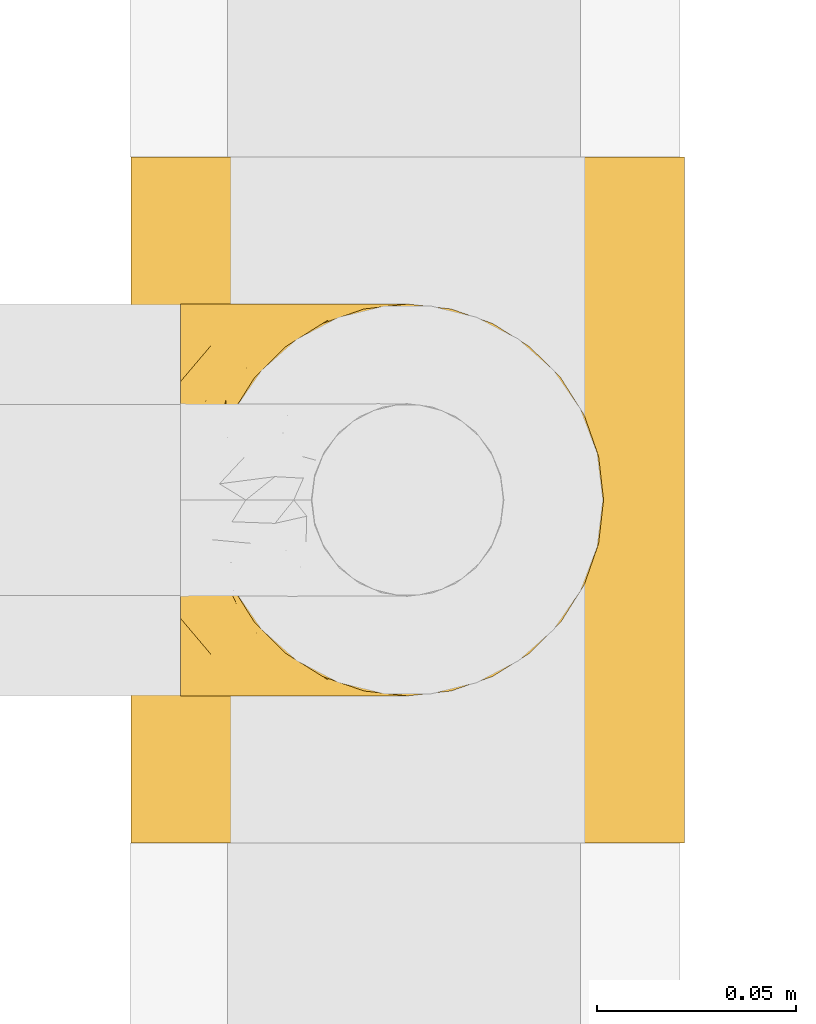
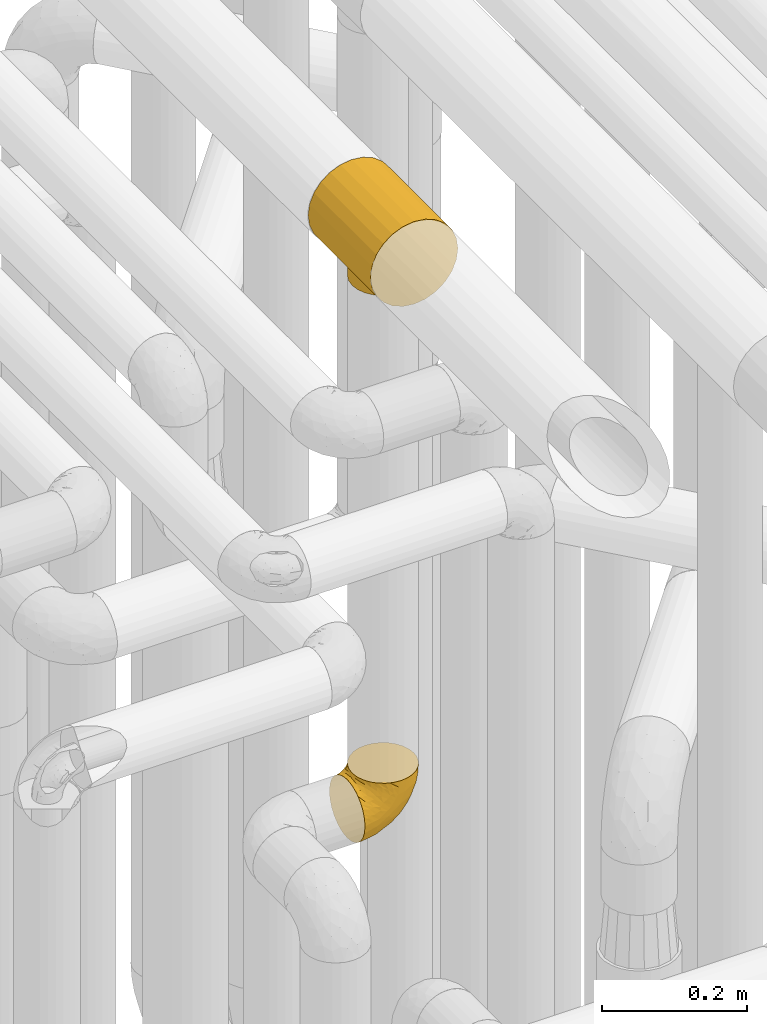
# One storey, part 199 of 827: 2 coverings.
"""IFC2X3 building model written with IfcOpenShell, lengths in millimetres."""

from ifc_helpers import new_model, entity, si_unit, converted_unit, derived_unit, direction, frame, origin, place, context, subcontext, project, spatial, faceted_brep, element, save


model = new_model("IFC2X3")

# Units and contexts
model_context = context("Model", 3, precision=0.01, world=origin(), true_north=direction((6.12303176911189e-17, 1.0)))
body_context = subcontext(model_context, "Body", "Model", "MODEL_VIEW")
ifc_project = project(units=[si_unit("LENGTHUNIT", "METRE", prefix="MILLI"), si_unit("AREAUNIT", "SQUARE_METRE"), si_unit("VOLUMEUNIT", "CUBIC_METRE"), converted_unit("PLANEANGLEUNIT", "DEGREE", entity("IfcRatioMeasure", 0.0174532925199433), si_unit("PLANEANGLEUNIT", "RADIAN"), dimensions=[0, 0, 0, 0, 0, 0, 0]), si_unit("MASSUNIT", "GRAM", prefix="KILO"), derived_unit("MASSDENSITYUNIT", [(si_unit("MASSUNIT", "GRAM", prefix="KILO"), 1), (si_unit("LENGTHUNIT", "METRE"), -3)]), derived_unit("MOMENTOFINERTIAUNIT", [(si_unit("LENGTHUNIT", "METRE"), 4)]), si_unit("TIMEUNIT", "SECOND"), si_unit("FREQUENCYUNIT", "HERTZ"), si_unit("THERMODYNAMICTEMPERATUREUNIT", "DEGREE_CELSIUS"), derived_unit("THERMALTRANSMITTANCEUNIT", [(si_unit("MASSUNIT", "GRAM", prefix="KILO"), 1), (si_unit("THERMODYNAMICTEMPERATUREUNIT", "KELVIN"), -1), (si_unit("TIMEUNIT", "SECOND"), -3)]), derived_unit("VOLUMETRICFLOWRATEUNIT", [(si_unit("LENGTHUNIT", "METRE"), 3), (si_unit("TIMEUNIT", "SECOND"), -1)]), derived_unit("MASSFLOWRATEUNIT", [(si_unit("MASSUNIT", "GRAM", prefix="KILO"), 1), (si_unit("TIMEUNIT", "SECOND"), -1)]), derived_unit("ROTATIONALFREQUENCYUNIT", [(si_unit("TIMEUNIT", "SECOND"), -1)]), si_unit("ELECTRICCURRENTUNIT", "AMPERE"), si_unit("ELECTRICVOLTAGEUNIT", "VOLT"), si_unit("POWERUNIT", "WATT"), si_unit("FORCEUNIT", "NEWTON", prefix="KILO"), si_unit("ILLUMINANCEUNIT", "LUX"), si_unit("LUMINOUSFLUXUNIT", "LUMEN"), si_unit("LUMINOUSINTENSITYUNIT", "CANDELA"), derived_unit("USERDEFINED", [(si_unit("MASSUNIT", "GRAM", prefix="KILO"), -1), (si_unit("LENGTHUNIT", "METRE"), -2), (si_unit("TIMEUNIT", "SECOND"), 3), (si_unit("LUMINOUSFLUXUNIT", "LUMEN"), 1)]), derived_unit("LINEARVELOCITYUNIT", [(si_unit("LENGTHUNIT", "METRE"), 1), (si_unit("TIMEUNIT", "SECOND"), -1)]), si_unit("PRESSUREUNIT", "PASCAL"), derived_unit("USERDEFINED", [(si_unit("LENGTHUNIT", "METRE"), -2), (si_unit("MASSUNIT", "GRAM", prefix="KILO"), 1), (si_unit("TIMEUNIT", "SECOND"), -2)]), derived_unit("LINEARFORCEUNIT", [(si_unit("MASSUNIT", "GRAM", prefix="KILO"), 1), (si_unit("LENGTHUNIT", "METRE"), 1), (si_unit("TIMEUNIT", "SECOND"), -2), (si_unit("LENGTHUNIT", "METRE"), -1)]), derived_unit("PLANARFORCEUNIT", [(si_unit("MASSUNIT", "GRAM", prefix="KILO"), 1), (si_unit("LENGTHUNIT", "METRE"), 1), (si_unit("TIMEUNIT", "SECOND"), -2), (si_unit("LENGTHUNIT", "METRE"), -2)])], contexts=[model_context])

# Site, building, storey
site_placement = place(None, origin())
site = spatial("IfcSite", under=ifc_project, at=site_placement, CompositionType="ELEMENT")
building_placement = place(site_placement, origin())
building = spatial("IfcBuilding", under=site, at=building_placement, CompositionType="ELEMENT")
storey_placement = place(building_placement, frame((0.0, 0.0, 28200.0)))
storey = spatial("IfcBuildingStorey", under=building, at=storey_placement, Name="08", CompositionType="ELEMENT", Elevation=28200.0)

# Coverings
covering_1_placement = place(storey_placement, frame((35847.93, 10720.2, 3477.0)))
element("IfcCovering", 1, at=covering_1_placement, inside=storey, Name=":ADSK_", ObjectType=":ADSK_", PredefinedType="INSULATION", context=body_context, shape_type="Brep", body=[
    faceted_brep([(138.13, 0.0, 90.97), (131.19, 0.0, 107.73), (120.15, 0.0, 122.11), (105.77, 0.0, 133.15), (89.02, 0.0, 140.08), (71.05, 0.0, 142.45), (53.07, 0.0, 140.08), (36.32, 0.0, 133.15), (21.94, 0.0, 122.11), (10.9, 0.0, 107.73), (3.96, 0.0, 90.97), (1.6, 0.0, 73.0), (3.96, 0.0, 55.03), (10.9, 0.0, 38.28), (21.94, 0.0, 23.89), (36.32, 0.0, 12.85), (44.7, 0.0, 9.39), (53.07, 0.0, 5.92), (62.06, 0.0, 4.73), (71.05, 0.0, 3.55), (80.03, 0.0, 4.73), (89.02, 0.0, 5.92), (97.4, 0.0, 9.39), (105.77, 0.0, 12.85), (120.15, 0.0, 23.89), (131.19, 0.0, 38.28), (138.13, 0.0, 55.03), (140.5, 0.0, 73.0), (21.94, 172.0, 122.11), (36.32, 172.0, 133.15), (53.07, 172.0, 140.08), (71.05, 172.0, 142.45), (89.02, 172.0, 140.08), (105.77, 172.0, 133.15), (120.15, 172.0, 122.11), (131.19, 172.0, 107.72), (138.13, 172.0, 90.97), (140.5, 172.0, 73.0), (138.13, 172.0, 55.03), (131.19, 172.0, 38.27), (120.15, 172.0, 23.89), (105.77, 172.0, 12.85), (97.4, 172.0, 9.39), (89.02, 172.0, 5.92), (80.03, 172.0, 4.73), (71.05, 172.0, 3.55), (62.06, 172.0, 4.73), (53.07, 172.0, 5.92), (44.7, 172.0, 9.39), (36.32, 172.0, 12.85), (21.94, 172.0, 23.89), (10.9, 172.0, 38.27), (3.96, 172.0, 55.03), (1.6, 172.0, 73.0), (3.96, 172.0, 90.97), (10.9, 172.0, 107.72), (32.61, 116.64, 15.15), (26.91, 107.63, 19.38), (49.21, 41.97, 7.07), (23.21, 97.28, 22.65), (59.7, 133.82, 4.48), (21.9, 86.0, 23.93), (23.21, 74.72, 22.65), (59.7, 38.18, 4.48), (65.38, 37.51, 4.02), (71.05, 36.85, 3.55), (32.61, 55.36, 15.15), (26.91, 64.37, 19.38), (40.09, 124.18, 10.83), (49.21, 130.03, 7.07), (71.05, 135.15, 3.55), (65.38, 134.49, 4.02), (54.46, 131.93, 5.78), (40.09, 47.82, 10.83), (54.46, 40.07, 5.78), (82.39, 133.82, 4.48), (102.0, 124.18, 10.83), (92.88, 130.03, 7.07), (87.64, 131.93, 5.78), (76.72, 37.51, 4.02), (82.39, 38.18, 4.48), (102.0, 47.82, 10.83), (92.88, 41.97, 7.07), (109.48, 55.36, 15.15), (87.64, 40.07, 5.78), (109.48, 116.64, 15.15), (115.18, 107.63, 19.38), (118.88, 97.28, 22.65), (76.72, 134.49, 4.02), (120.2, 86.0, 23.93), (115.18, 64.37, 19.38), (118.88, 74.72, 22.65), (23.57, 98.72, 0.0), (28.48, 110.57, 0.0), (36.29, 120.75, 0.0), (46.47, 128.57, 0.0), (52.4, 131.02, 0.0), (58.32, 133.48, 0.0), (64.68, 134.31, 0.0), (71.05, 135.15, 0.0), (77.41, 134.31, 0.0), (83.77, 133.48, 0.0), (89.69, 131.02, 0.0), (95.62, 128.57, 0.0), (105.8, 120.75, 0.0), (113.61, 110.57, 0.0), (118.52, 98.72, 0.0), (120.2, 86.0, 0.0), (118.52, 73.28, 0.0), (113.61, 61.42, 0.0), (105.8, 51.25, 0.0), (95.62, 43.43, 0.0), (89.69, 40.98, 0.0), (83.77, 38.52, 0.0), (77.41, 37.69, 0.0), (71.05, 36.85, 0.0), (64.68, 37.69, 0.0), (58.32, 38.52, 0.0), (52.4, 40.98, 0.0), (46.47, 43.43, 0.0), (36.29, 51.25, 0.0), (28.48, 61.42, 0.0), (23.57, 73.28, 0.0), (21.9, 86.0, 0.0)], [[[0, 1, 2, 3, 4, 5, 6, 7, 8, 9, 10, 11, 12, 13, 14, 15, 16, 17, 18, 19, 20, 21, 22, 23, 24, 25, 26, 27]], [[28, 29, 30, 31, 32, 33, 34, 35, 36, 37, 38, 39, 40, 41, 42, 43, 44, 45, 46, 47, 48, 49, 50, 51, 52, 53, 54, 55]], [[29, 28, 8, 7]], [[5, 31, 30, 6]], [[7, 6, 30, 29]], [[9, 55, 54, 10]], [[10, 54, 53, 11]], [[8, 28, 55, 9]], [[52, 12, 11, 53]], [[51, 13, 12, 52]], [[50, 56, 57]], [[56, 50, 49]], [[58, 17, 16]], [[57, 59, 50]], [[60, 47, 46]], [[51, 50, 61]], [[50, 59, 61]], [[61, 62, 14]], [[18, 63, 64, 65]], [[66, 14, 67]], [[67, 14, 62]], [[68, 48, 69]], [[61, 14, 13]], [[61, 13, 51]], [[48, 68, 49]], [[69, 48, 47]], [[45, 70, 46]], [[65, 19, 18]], [[46, 70, 71, 60]], [[47, 60, 72, 69]], [[66, 73, 15]], [[73, 16, 15]], [[16, 73, 58]], [[66, 15, 14]], [[18, 17, 63]], [[17, 58, 74, 63]], [[68, 56, 49]], [[45, 44, 70]], [[65, 20, 19]], [[75, 44, 43]], [[41, 76, 42]], [[77, 42, 76]], [[43, 77, 78, 75]], [[20, 65, 79, 80]], [[81, 23, 22]], [[22, 21, 82]], [[23, 81, 83]], [[21, 80, 84, 82]], [[85, 76, 41]], [[86, 85, 40]], [[87, 86, 40]], [[44, 75, 88, 70]], [[39, 38, 26, 25]], [[89, 40, 39]], [[87, 40, 89]], [[85, 41, 40]], [[26, 38, 37, 27]], [[90, 91, 24]], [[80, 21, 20]], [[83, 24, 23]], [[24, 83, 90]], [[91, 89, 24]], [[77, 43, 42]], [[89, 25, 24]], [[89, 39, 25]], [[81, 22, 82]], [[0, 36, 35, 1]], [[1, 35, 34, 2]], [[37, 36, 0, 27]], [[3, 33, 32, 4]], [[4, 32, 31, 5]], [[2, 34, 33, 3]], [[92, 93, 94, 95, 96, 97, 98, 99, 100, 101, 102, 103, 104, 105, 106, 107, 108, 109, 110, 111, 112, 113, 114, 115, 116, 117, 118, 119, 120, 121, 122, 123]], [[60, 98, 97]], [[69, 96, 95]], [[99, 71, 70]], [[99, 98, 71]], [[97, 72, 60]], [[68, 69, 95]], [[96, 72, 97]], [[98, 60, 71]], [[95, 94, 68]], [[56, 94, 93]], [[92, 123, 59]], [[57, 93, 92]], [[96, 69, 72]], [[56, 93, 57]], [[59, 57, 92]], [[61, 59, 123]], [[94, 56, 68]], [[62, 123, 122]], [[67, 122, 121]], [[61, 123, 62]], [[115, 64, 116]], [[62, 122, 67]], [[121, 66, 67]], [[121, 120, 66]], [[73, 120, 119]], [[63, 74, 117]], [[64, 115, 65]], [[63, 117, 116]], [[58, 73, 119]], [[58, 119, 118]], [[63, 116, 64]], [[118, 74, 58]], [[117, 74, 118]], [[120, 73, 66]], [[80, 114, 113]], [[82, 112, 111]], [[115, 79, 65]], [[115, 114, 79]], [[113, 84, 80]], [[81, 82, 111]], [[112, 84, 113]], [[114, 80, 79]], [[111, 110, 81]], [[83, 110, 109]], [[109, 108, 90]], [[107, 91, 108]], [[112, 82, 84]], [[83, 109, 90]], [[91, 90, 108]], [[89, 91, 107]], [[110, 83, 81]], [[87, 107, 106]], [[86, 106, 105]], [[89, 107, 87]], [[99, 88, 100]], [[87, 106, 86]], [[105, 85, 86]], [[105, 104, 85]], [[76, 104, 103]], [[75, 78, 101]], [[88, 99, 70]], [[75, 101, 100]], [[77, 76, 103]], [[77, 103, 102]], [[75, 100, 88]], [[102, 78, 77]], [[101, 78, 102]], [[104, 76, 85]]]),
])
covering_2_placement = place(storey_placement, frame((35860.38, 10755.46, 2549.25)))
element("IfcCovering", 2, at=covering_2_placement, inside=storey, Name=":ADSK_", ObjectType=":ADSK_", PredefinedType="INSULATION", context=body_context, shape_type="Brep", body=[
    faceted_brep([(58.6, 1.6, 107.75), (69.54, 2.83, 107.75), (79.93, 6.47, 107.75), (89.25, 12.32, 107.75), (97.03, 20.11, 107.75), (102.88, 29.43, 107.75), (106.51, 39.81, 107.75), (107.75, 50.75, 107.75), (106.51, 61.69, 107.75), (102.87, 72.08, 107.75), (97.02, 81.4, 107.75), (89.23, 89.18, 107.75), (79.91, 95.03, 107.75), (69.53, 98.66, 107.75), (58.6, 99.9, 107.75), (52.89, 99.25, 107.75), (47.65, 98.66, 107.75), (42.46, 96.84, 107.75), (37.26, 95.02, 107.75), (27.94, 89.17, 107.75), (20.16, 81.38, 107.75), (14.31, 72.06, 107.75), (10.68, 61.68, 107.75), (9.45, 50.75, 107.75), (10.68, 39.8, 107.75), (14.32, 29.41, 107.75), (20.17, 20.09, 107.75), (27.96, 12.31, 107.75), (37.28, 6.46, 107.75), (42.47, 4.64, 107.75), (47.66, 2.83, 107.75), (52.89, 2.24, 107.75), (55.75, 1.92, 107.75), (1.6, 63.47, 98.22), (1.6, 75.32, 93.31), (1.6, 80.41, 89.4), (1.6, 85.5, 85.5), (1.6, 89.4, 80.41), (1.6, 93.31, 75.32), (1.6, 95.77, 69.39), (1.6, 98.22, 63.47), (1.6, 99.14, 56.48), (1.6, 99.52, 53.61), (1.6, 99.9, 50.75), (1.6, 98.22, 38.02), (1.6, 93.31, 26.17), (1.6, 85.5, 15.99), (1.6, 75.32, 8.18), (1.6, 63.47, 3.27), (1.6, 50.75, 1.6), (1.6, 38.02, 3.27), (1.6, 26.17, 8.18), (1.6, 15.99, 15.99), (1.6, 8.18, 26.17), (1.6, 3.27, 38.02), (1.6, 1.6, 50.75), (1.6, 2.35, 56.48), (1.6, 3.27, 63.47), (1.6, 5.73, 69.39), (1.6, 8.18, 75.32), (1.6, 12.09, 80.41), (1.6, 15.99, 85.5), (1.6, 21.08, 89.4), (1.6, 26.17, 93.31), (1.6, 38.02, 98.22), (1.6, 50.75, 99.9), (69.96, 42.18, 27.53), (59.59, 28.42, 25.32), (51.96, 37.78, 16.29), (34.4, 50.75, 6.79), (23.37, 42.85, 4.51), (13.68, 50.75, 3.51), (41.52, 24.75, 17.47), (26.26, 33.81, 7.6), (20.18, 22.57, 12.27), (72.33, 7.18, 70.89), (65.88, 2.73, 87.17), (57.55, 3.09, 67.3), (23.76, 6.92, 31.65), (46.5, 11.58, 33.58), (46.57, 5.17, 47.23), (21.17, 2.71, 43.26), (23.41, 1.6, 55.08), (17.92, 1.6, 53.99), (12.43, 1.6, 52.9), (9.72, 1.6, 52.36), (7.01, 1.6, 51.82), (26.77, 14.18, 21.5), (76.59, 5.88, 89.94), (95.55, 41.06, 60.45), (102.57, 36.25, 83.0), (92.89, 28.62, 64.79), (54.26, 1.6, 85.93), (51.17, 1.6, 81.31), (48.08, 1.6, 76.69), (44.99, 1.6, 72.06), (41.9, 1.6, 67.44), (85.16, 10.85, 88.74), (85.97, 38.35, 45.98), (59.58, 9.6, 47.13), (99.5, 26.24, 89.4), (105.83, 50.75, 95.66), (53.59, 19.31, 28.5), (67.0, 16.41, 42.81), (71.56, 24.56, 38.28), (87.47, 50.75, 45.35), (75.73, 50.75, 33.61), (92.24, 18.47, 82.57), (58.06, 1.6, 105.04), (57.52, 1.6, 102.33), (56.44, 1.6, 96.91), (55.35, 1.6, 91.42), (81.33, 14.36, 65.92), (80.35, 20.64, 53.11), (39.44, 2.32, 54.37), (102.55, 50.75, 74.94), (37.28, 1.6, 64.35), (32.65, 1.6, 61.26), (28.03, 1.6, 58.17), (63.99, 50.75, 21.87), (74.55, 33.88, 34.79), (83.62, 29.24, 48.48), (95.01, 50.75, 60.15), (49.19, 50.75, 14.33), (46.96, 2.8, 99.07), (8.77, 2.48, 60.55), (18.28, 2.7, 64.18), (11.68, 3.2, 64.36), (11.79, 32.98, 103.17), (15.69, 24.67, 101.69), (42.49, 2.95, 87.75), (47.41, 2.19, 89.38), (7.94, 17.92, 88.34), (9.27, 12.02, 82.14), (7.98, 25.73, 94.51), (13.4, 16.63, 89.64), (13.04, 25.6, 98.41), (7.36, 36.72, 99.71), (23.46, 10.66, 89.37), (30.46, 6.87, 88.21), (26.54, 11.12, 95.2), (6.76, 10.31, 79.14), (26.46, 12.84, 101.22), (20.77, 17.38, 99.41), (20.68, 9.74, 84.72), (40.26, 4.63, 97.47), (7.15, 50.75, 102.19), (9.28, 42.52, 104.02), (38.78, 3.12, 82.66), (18.27, 17.58, 95.42), (31.78, 3.97, 78.67), (12.75, 5.94, 72.69), (22.96, 2.73, 66.46), (17.55, 6.23, 75.3), (27.63, 3.45, 72.74), (15.23, 10.84, 82.93), (33.25, 7.98, 99.27), (32.43, 7.33, 93.51), (27.9, 2.39, 67.35), (7.97, 75.76, 94.51), (15.22, 90.65, 82.94), (7.93, 83.57, 88.33), (13.38, 84.85, 89.64), (13.12, 71.05, 103.62), (42.49, 98.54, 87.74), (47.4, 99.3, 89.38), (51.17, 99.9, 81.31), (40.24, 96.86, 97.47), (20.76, 84.1, 99.41), (12.43, 99.9, 52.9), (7.01, 99.9, 51.82), (4.31, 99.9, 51.28), (26.44, 88.63, 101.21), (26.52, 90.36, 95.19), (11.68, 98.29, 64.36), (12.75, 95.55, 72.69), (9.27, 89.47, 82.13), (17.55, 95.26, 75.3), (6.76, 91.18, 79.14), (33.21, 93.49, 99.28), (32.41, 94.15, 93.51), (8.77, 99.01, 60.55), (22.96, 98.76, 66.46), (18.48, 98.85, 63.96), (56.44, 99.9, 96.91), (46.95, 98.69, 99.06), (7.36, 64.78, 99.7), (17.92, 99.9, 53.99), (23.41, 99.9, 55.08), (9.85, 62.91, 103.3), (57.52, 99.9, 102.33), (56.98, 99.9, 99.62), (48.08, 99.9, 76.69), (38.78, 98.37, 82.66), (18.25, 83.9, 95.42), (44.99, 99.9, 72.06), (31.74, 97.51, 78.68), (30.45, 94.62, 88.2), (27.63, 98.04, 72.75), (20.65, 91.73, 84.74), (55.35, 99.9, 91.42), (54.26, 99.9, 85.93), (13.03, 75.87, 98.41), (23.44, 90.83, 89.37), (27.9, 99.1, 67.35), (32.65, 99.9, 61.26), (28.03, 99.9, 58.17), (37.28, 99.9, 64.35), (41.9, 99.9, 67.44), (39.74, 99.09, 54.08), (23.37, 58.64, 4.51), (26.77, 87.31, 21.5), (46.18, 89.93, 33.43), (53.54, 82.22, 28.5), (41.53, 76.74, 17.47), (59.61, 73.12, 25.36), (76.79, 95.54, 90.18), (66.11, 98.7, 86.97), (21.17, 98.79, 43.26), (51.96, 63.71, 16.29), (26.26, 67.68, 7.6), (20.18, 78.92, 12.27), (23.76, 94.57, 31.65), (92.88, 72.88, 64.79), (102.57, 65.25, 83.0), (95.54, 60.44, 60.44), (71.63, 76.94, 38.35), (74.55, 67.61, 34.8), (72.51, 94.38, 71.54), (69.96, 59.31, 27.53), (92.23, 83.03, 82.57), (85.15, 90.66, 88.74), (80.45, 80.8, 53.19), (83.65, 72.22, 48.49), (57.57, 98.39, 67.28), (63.68, 92.31, 52.32), (85.95, 63.11, 45.94), (99.49, 75.27, 89.4), (81.23, 87.15, 65.75), (47.07, 96.03, 46.73), (66.99, 85.1, 42.82)], [[[0, 1, 2, 3, 4, 5, 6, 7, 8, 9, 10, 11, 12, 13, 14, 15, 16, 17, 18, 19, 20, 21, 22, 23, 24, 25, 26, 27, 28, 29, 30, 31, 32]], [[33, 34, 35, 36, 37, 38, 39, 40, 41, 42, 43, 44, 45, 46, 47, 48, 49, 50, 51, 52, 53, 54, 55, 56, 57, 58, 59, 60, 61, 62, 63, 64, 65]], [[66, 67, 68]], [[69, 70, 71]], [[68, 72, 73]], [[73, 72, 74]], [[75, 76, 77]], [[78, 79, 80]], [[51, 50, 73]], [[81, 82, 83, 84, 85, 86, 55]], [[52, 87, 53]], [[74, 52, 51]], [[2, 1, 88]], [[89, 90, 91]], [[77, 92, 93, 94, 95, 96]], [[55, 54, 81]], [[78, 53, 87]], [[5, 90, 6]], [[88, 76, 75]], [[97, 3, 2]], [[89, 91, 98]], [[99, 80, 79]], [[90, 5, 100]], [[74, 87, 52]], [[100, 5, 4]], [[90, 101, 6]], [[79, 102, 103]], [[102, 67, 104]], [[105, 98, 106]], [[107, 4, 3]], [[76, 0, 108, 109, 110, 111, 92]], [[107, 112, 113]], [[114, 77, 96]], [[89, 115, 90]], [[114, 96, 116, 117, 118, 82]], [[75, 97, 88]], [[119, 66, 68]], [[50, 71, 70]], [[100, 91, 90]], [[99, 77, 80]], [[102, 104, 103]], [[97, 107, 3]], [[80, 81, 78]], [[107, 97, 112]], [[68, 73, 70]], [[66, 98, 120]], [[78, 81, 54]], [[114, 81, 80]], [[53, 78, 54]], [[78, 87, 79]], [[102, 87, 72]], [[79, 103, 99]], [[4, 107, 100]], [[91, 100, 107]], [[88, 97, 2]], [[112, 97, 75]], [[99, 112, 75]], [[103, 104, 113]], [[91, 121, 98]], [[89, 105, 122, 115]], [[101, 90, 115]], [[101, 7, 6]], [[88, 1, 76]], [[0, 76, 1]], [[92, 77, 76]], [[73, 74, 51]], [[87, 74, 72]], [[81, 114, 82]], [[77, 114, 80]], [[87, 102, 79]], [[67, 102, 72]], [[68, 67, 72]], [[67, 120, 104]], [[120, 121, 104]], [[104, 121, 113]], [[121, 120, 98]], [[91, 107, 113]], [[91, 113, 121]], [[103, 113, 112]], [[106, 98, 66]], [[105, 89, 98]], [[106, 66, 119]], [[67, 66, 120]], [[68, 69, 123, 119]], [[50, 49, 71]], [[50, 70, 73]], [[112, 99, 103]], [[77, 99, 75]], [[69, 68, 70]], [[29, 124, 110]], [[84, 83, 125]], [[126, 82, 118]], [[59, 58, 127]], [[25, 128, 129]], [[130, 93, 131]], [[132, 62, 133]], [[134, 135, 136]], [[137, 65, 64]], [[64, 134, 137]], [[138, 139, 140]], [[111, 110, 124, 92]], [[134, 136, 137]], [[134, 64, 63]], [[141, 61, 60]], [[125, 58, 57]], [[142, 143, 140]], [[142, 26, 143]], [[127, 83, 82]], [[28, 124, 29]], [[108, 0, 32, 31, 30, 110, 109]], [[30, 29, 110]], [[135, 144, 138]], [[28, 145, 124]], [[57, 56, 55, 86, 85, 84]], [[146, 147, 23]], [[24, 23, 147]], [[25, 143, 26]], [[95, 94, 148]], [[24, 128, 25]], [[149, 138, 143]], [[124, 145, 131]], [[127, 58, 125]], [[150, 148, 139]], [[127, 126, 151]], [[151, 59, 127]], [[152, 151, 126]], [[153, 154, 155]], [[153, 133, 141]], [[145, 28, 27]], [[142, 156, 27]], [[157, 148, 130]], [[61, 133, 62]], [[134, 132, 135]], [[147, 128, 24]], [[65, 137, 146]], [[146, 137, 147]], [[128, 137, 136]], [[137, 128, 147]], [[128, 136, 129]], [[149, 129, 136]], [[25, 129, 143]], [[158, 152, 117]], [[152, 118, 117]], [[153, 151, 152]], [[158, 116, 154]], [[144, 150, 138]], [[153, 152, 158]], [[133, 153, 155]], [[133, 155, 132]], [[60, 151, 141]], [[135, 132, 155]], [[134, 63, 132]], [[144, 135, 155]], [[135, 138, 149]], [[155, 154, 144]], [[150, 154, 96]], [[154, 150, 144]], [[148, 94, 130]], [[82, 126, 127]], [[118, 152, 126]], [[150, 96, 95]], [[139, 148, 157]], [[150, 95, 148]], [[93, 92, 131]], [[130, 145, 156]], [[130, 94, 93]], [[84, 125, 57]], [[127, 125, 83]], [[140, 139, 157]], [[150, 139, 138]], [[140, 157, 142]], [[138, 140, 143]], [[156, 142, 157]], [[27, 26, 142]], [[130, 156, 157]], [[145, 27, 156]], [[132, 63, 62]], [[124, 131, 92]], [[130, 131, 145]], [[129, 149, 143]], [[135, 149, 136]], [[141, 133, 61]], [[60, 59, 151]], [[141, 151, 153]], [[116, 96, 154]], [[153, 158, 154]], [[158, 117, 116]], [[34, 33, 159]], [[160, 161, 162]], [[22, 21, 163]], [[164, 165, 166]], [[19, 18, 167]], [[168, 21, 20]], [[42, 41, 40, 169, 170, 171, 43]], [[172, 173, 168]], [[174, 38, 175]], [[176, 177, 178]], [[179, 164, 180]], [[40, 181, 169]], [[182, 183, 175]], [[17, 184, 185]], [[65, 146, 186]], [[187, 174, 188]], [[23, 22, 189]], [[174, 39, 38]], [[15, 14, 190, 191, 184, 16]], [[181, 40, 39]], [[192, 193, 164]], [[194, 163, 168]], [[33, 186, 159]], [[180, 173, 172]], [[195, 196, 193]], [[18, 185, 167]], [[173, 180, 197]], [[198, 199, 196]], [[200, 201, 185, 184]], [[184, 17, 16]], [[18, 17, 185]], [[202, 159, 186]], [[194, 168, 203]], [[189, 163, 202]], [[204, 205, 182]], [[187, 181, 174]], [[160, 177, 176]], [[206, 183, 182]], [[206, 182, 205]], [[201, 165, 185]], [[165, 164, 167]], [[172, 179, 180]], [[202, 194, 162]], [[176, 161, 160]], [[65, 186, 33]], [[163, 189, 22]], [[175, 177, 182]], [[174, 183, 188]], [[177, 198, 204]], [[199, 160, 162]], [[198, 207, 204]], [[175, 38, 37]], [[198, 177, 160]], [[178, 177, 175]], [[176, 35, 161]], [[34, 159, 161]], [[162, 161, 159]], [[202, 162, 159]], [[199, 162, 203]], [[196, 199, 203]], [[198, 160, 199]], [[193, 197, 180]], [[208, 198, 196]], [[188, 183, 206]], [[175, 183, 174]], [[193, 192, 195]], [[195, 208, 196]], [[197, 196, 203]], [[180, 164, 193]], [[168, 163, 21]], [[166, 165, 201]], [[166, 192, 164]], [[189, 202, 186]], [[186, 146, 189]], [[23, 189, 146]], [[174, 181, 39]], [[169, 181, 187]], [[196, 197, 193]], [[173, 203, 168]], [[203, 173, 197]], [[172, 168, 20]], [[20, 19, 172]], [[179, 172, 19]], [[19, 167, 179]], [[164, 179, 167]], [[35, 176, 36]], [[35, 34, 161]], [[185, 165, 167]], [[162, 194, 203]], [[163, 194, 202]], [[176, 178, 36]], [[37, 36, 178]], [[175, 37, 178]], [[177, 204, 182]], [[207, 198, 208]], [[207, 205, 204]], [[209, 188, 206, 205, 207, 208]], [[48, 210, 71]], [[211, 212, 213]], [[214, 213, 215]], [[216, 217, 13]], [[218, 43, 171, 170, 169, 187, 188]], [[219, 220, 214]], [[47, 46, 221]], [[210, 48, 220]], [[211, 222, 212]], [[222, 45, 44]], [[221, 220, 47]], [[47, 220, 48]], [[221, 211, 214]], [[223, 224, 225]], [[211, 46, 45]], [[226, 227, 215]], [[43, 218, 44]], [[217, 216, 228]], [[219, 215, 229]], [[14, 13, 217]], [[224, 9, 8]], [[10, 230, 11]], [[11, 231, 12]], [[232, 223, 233]], [[234, 208, 195, 192, 166, 201]], [[235, 234, 228]], [[222, 44, 218]], [[106, 229, 236]], [[224, 237, 9]], [[231, 238, 228]], [[9, 237, 10]], [[115, 224, 101]], [[239, 234, 235]], [[231, 11, 230]], [[223, 230, 237]], [[224, 8, 101]], [[223, 236, 233]], [[225, 115, 122, 105]], [[216, 12, 231]], [[209, 234, 239]], [[210, 219, 69]], [[219, 214, 215]], [[229, 119, 219]], [[209, 218, 188]], [[239, 212, 222]], [[239, 222, 218]], [[45, 222, 211]], [[235, 212, 239]], [[213, 212, 240]], [[223, 237, 224]], [[230, 10, 237]], [[238, 231, 230]], [[216, 231, 228]], [[232, 230, 223]], [[235, 238, 240]], [[115, 225, 224]], [[233, 236, 227]], [[8, 7, 101]], [[234, 209, 208]], [[218, 209, 239]], [[217, 228, 234]], [[13, 12, 216]], [[234, 201, 217]], [[217, 201, 200, 184, 191, 190, 14]], [[211, 221, 46]], [[220, 221, 214]], [[71, 210, 69]], [[71, 49, 48]], [[219, 210, 220]], [[226, 215, 213]], [[211, 213, 214]], [[226, 213, 240]], [[215, 227, 229]], [[232, 240, 238]], [[233, 227, 226]], [[232, 233, 226]], [[236, 223, 225]], [[240, 232, 226]], [[232, 238, 230]], [[225, 105, 236]], [[236, 105, 106]], [[236, 229, 227]], [[123, 69, 219, 119]], [[106, 119, 229]], [[238, 235, 228]], [[212, 235, 240]]]),
])

save(model, "model.ifc")
